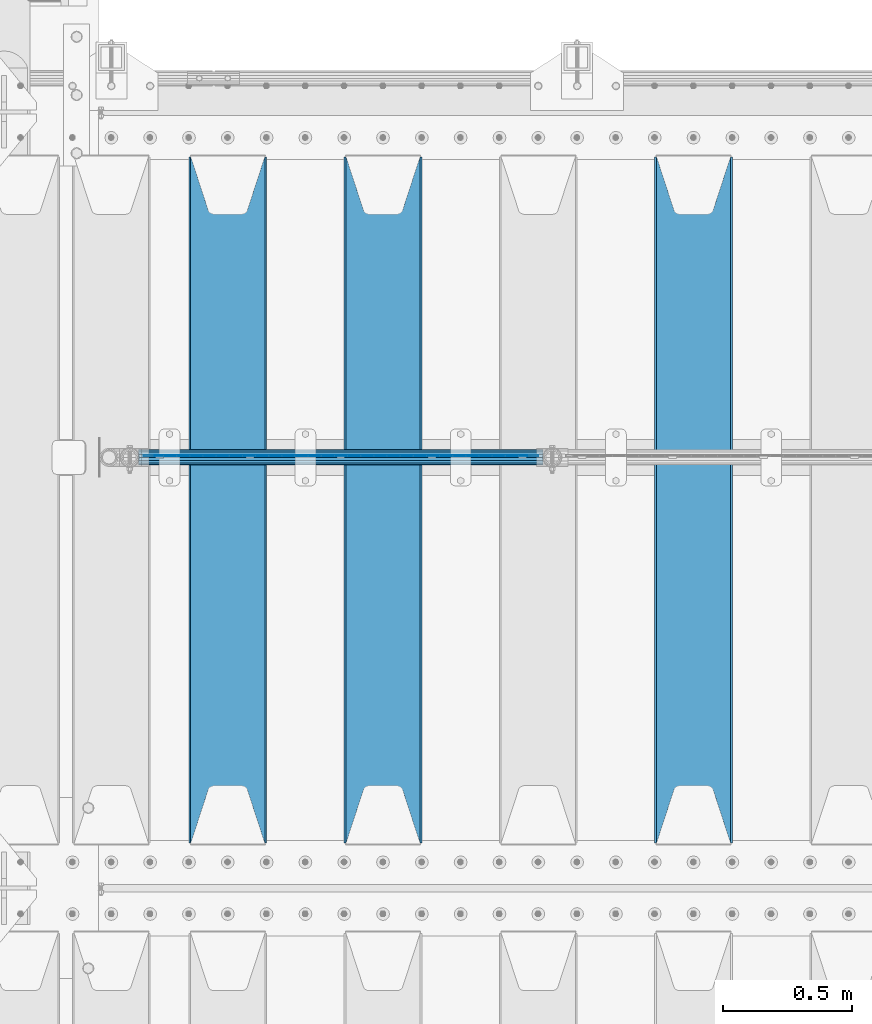
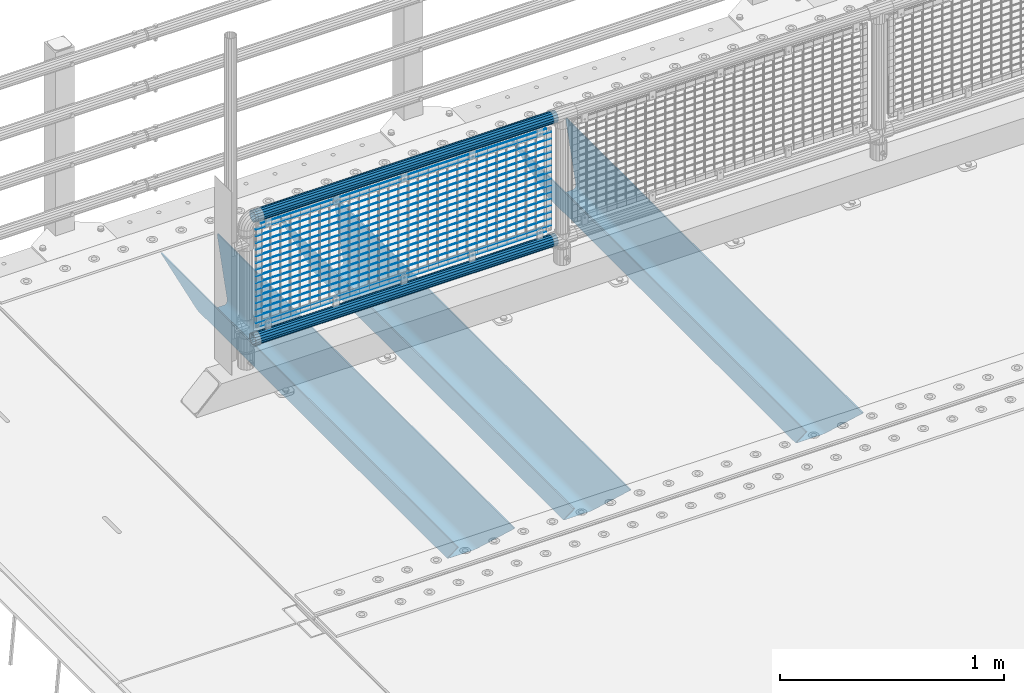
# One storey, part 128 of 270: 22 beams.
"""IFC2X3 building model written with IfcOpenShell, lengths in millimetres."""

from ifc_helpers import new_model, si_unit, frame, origin_with_axes, place, context, subcontext, project, spatial, faceted_brep, material, type_object, element, save


model = new_model("IFC2X3")

# Units and contexts
model_context = context("Model", 3, precision=1e-05, world=origin_with_axes())
body_context = subcontext(model_context, "Body", "Model", "MODEL_VIEW")
ifc_project = project(units=[si_unit("LENGTHUNIT", "METRE", prefix="MILLI"), si_unit("AREAUNIT", "SQUARE_METRE"), si_unit("VOLUMEUNIT", "CUBIC_METRE"), si_unit("MASSUNIT", "GRAM", prefix="KILO"), si_unit("TIMEUNIT", "SECOND"), si_unit("PLANEANGLEUNIT", "RADIAN"), si_unit("SOLIDANGLEUNIT", "STERADIAN"), si_unit("THERMODYNAMICTEMPERATUREUNIT", "DEGREE_CELSIUS"), si_unit("LUMINOUSINTENSITYUNIT", "LUMEN")], contexts=[model_context])

# Site, building, storey
site_placement = place(None, origin_with_axes())
site = spatial("IfcSite", under=ifc_project, at=site_placement, CompositionType="ELEMENT")
building_placement = place(site_placement, origin_with_axes())
building = spatial("IfcBuilding", under=site, at=building_placement, Name="Standard", CompositionType="ELEMENT")
storey_placement = place(building_placement, origin_with_axes())
storey = spatial("IfcBuildingStorey", under=building, at=storey_placement, Name="Undefined", CompositionType="ELEMENT", Elevation=0.0)

# Beams
ifc_material_1 = material(Name="STEEL/S355N")
beam_type_1 = type_object("IfcBeamType", PredefinedType="NOTDEFINED")
beam_1_placement = place(storey_placement, frame((2800.0, -17825.0, -115.0), z_axis=(0.0, 0.0, 1.0), x_axis=(0.0, 1.0, 0.0)))
element("IfcBeam", 1, at=beam_1_placement, inside=storey, type_object=beam_type_1, material=ifc_material_1, context=body_context, shape_type="Brep", body=[
    faceted_brep([(0.0, 150.0, 115.0), (0.0, 143.689999999999, 115.0), (2650.00000000297, 143.689999999999, 115.0), (2650.00000000297, 150.0, 115.0), (2650.00000000297, 142.059565218398, 110.000000003096), (2650.00000000297, 148.3695652184, 110.000000003096), (2441.90079219209, -80.1103600731112, -98.0992078077845), (2437.7588105432, -77.5672621345584, -102.241189456673), (2434.06523489747, -74.4080125315522, -105.934765102404), (2430.9108609509, -70.710272125576, -109.089139048974), (2428.37322971128, -66.5649389910068, -111.626770288588), (2426.51472138055, -62.0739139532889, -113.485278619323), (2425.38102192092, -57.3475956567672, -114.618978078955), (2424.99999999987, -52.5021667386536, -115.0), (2424.99999999987, 52.5021667386536, -115.0), (2425.38102192092, 57.3475956567672, -114.618978078955), (2426.51472138055, 62.0739139532889, -113.485278619323), (2428.37322971128, 66.5649389910068, -111.626770288588), (2430.9108609509, 70.710272125576, -109.089139048974), (2434.06523489747, 74.4080125315522, -105.934765102404), (2437.7588105432, 77.5672621345584, -102.241189456673), (2441.90079219209, 80.1103600731112, -98.0992078077846), (2446.38936140511, 81.9747917625791, -93.6106385947584), (2448.2494850041, 76.2713538057251, -91.7505149957729), (2444.62967112263, 74.76777986261, -95.3703288772456), (2441.28936334126, 72.7168944282894, -98.710636658607), (2438.31067330439, 70.1691124903846, -101.689326695487), (2435.76682334747, 67.1870637758839, -104.233176652398), (2433.72034654133, 63.8440531834895, -106.279653458539), (2432.22154950042, 60.222258798236, -107.778450499454), (2431.30727574265, 56.4107117849089, -108.692724257221), (2430.99999999987, 52.5031078186876, -109.0), (2430.99999999987, -52.5031078186876, -109.0), (2431.30727574265, -56.4107117849089, -108.692724257221), (2432.22154950042, -60.222258798236, -107.778450499454), (2433.72034654133, -63.8440531834895, -106.279653458539), (2435.76682334747, -67.1870637758839, -104.233176652398), (2438.31067330438, -70.1691124903846, -101.689326695487), (2441.28936334126, -72.7168944282894, -98.7106366586071), (2444.62967112263, -74.76777986261, -95.3703288772457), (2448.2494850041, -76.2713538057251, -91.7505149957729), (2650.00000000297, -142.059565218398, 110.000000003096), (2650.00000000297, -148.3695652184, 110.000000003096), (2446.38936140511, -81.9747917625791, -93.6106385947584), (2650.00000000297, -143.689999999999, 115.0), (2650.00000000297, -150.0, 115.0), (0.0, -143.689999999999, 115.0), (0.0, -150.0, 115.0), (0.0, -148.369565218261, 110.000000002672), (203.610638597431, -81.9747917625791, -93.6106385947584), (208.099207810457, -80.1103600731112, -98.0992078077845), (212.241189459342, -77.5672621345584, -102.241189456673), (215.934765105078, -74.4080125315522, -105.934765102404), (219.089139051644, -70.710272125576, -109.089139048974), (221.626770291259, -66.5649389910068, -111.626770288588), (223.485278621993, -62.0739139532889, -113.485278619323), (224.618978081628, -57.3475956567672, -114.618978078955), (225.00000000267, -52.5021667386536, -115.0), (225.00000000267, 52.5021667386536, -115.0), (224.618978081628, 57.3475956567672, -114.618978078955), (223.485278621993, 62.0739139532889, -113.485278619323), (221.626770291259, 66.5649389910068, -111.626770288588), (219.089139051644, 70.710272125576, -109.089139048974), (215.934765105078, 74.4080125315522, -105.934765102404), (212.241189459342, 77.5672621345584, -102.241189456673), (208.099207810457, 80.1103600731112, -98.0992078077846), (203.610638597431, 81.9747917625791, -93.6106385947584), (0.0, 148.369565218261, 110.000000002672), (0.0, 142.05956521826, 110.000000002672), (201.750514998446, 76.2713538057251, -91.7505149957729), (205.370328879915, 74.76777986261, -95.3703288772456), (208.710636661279, 72.7168944282894, -98.710636658607), (211.689326698157, 70.1691124903846, -101.689326695487), (214.233176655071, 67.1870637758839, -104.233176652398), (216.27965346121, 63.8440531834895, -106.279653458539), (217.778450502126, 60.222258798236, -107.778450499454), (218.692724259894, 56.4107117849089, -108.692724257221), (219.00000000267, 52.5031078186876, -109.0), (219.00000000267, -52.5031078186876, -109.0), (218.692724259894, -56.4107117849089, -108.692724257221), (217.778450502123, -60.222258798236, -107.778450499454), (216.27965346121, -63.8440531834895, -106.279653458539), (214.233176655071, -67.1870637758839, -104.233176652398), (211.689326698157, -70.1691124903846, -101.689326695487), (208.710636661279, -72.7168944282894, -98.7106366586071), (205.370328879915, -74.76777986261, -95.3703288772457), (201.750514998446, -76.2713538057251, -91.7505149957729), (0.0, -142.05956521826, 110.000000002672)], [[[0, 1, 2, 3]], [[3, 2, 4, 5]], [[6, 7, 8, 9, 10, 11, 12, 13, 14, 15, 16, 17, 18, 19, 20, 21, 22, 5, 4, 23, 24, 25, 26, 27, 28, 29, 30, 31, 32, 33, 34, 35, 36, 37, 38, 39, 40, 41, 42, 43]], [[44, 45, 42, 41]], [[46, 47, 45, 44]], [[43, 42, 45, 47, 48, 49]], [[6, 43, 49, 50]], [[7, 6, 50, 51]], [[8, 7, 51, 52]], [[9, 8, 52, 53]], [[10, 9, 53, 54]], [[11, 10, 54, 55]], [[12, 11, 55, 56]], [[13, 12, 56, 57]], [[14, 13, 57, 58]], [[15, 14, 58, 59]], [[16, 15, 59, 60]], [[17, 16, 60, 61]], [[18, 17, 61, 62]], [[19, 18, 62, 63]], [[20, 19, 63, 64]], [[21, 20, 64, 65]], [[22, 21, 65, 66]], [[0, 3, 5, 22, 66, 67]], [[1, 0, 67, 68]], [[23, 4, 2, 1, 68, 69]], [[24, 23, 69, 70]], [[25, 24, 70, 71]], [[26, 25, 71, 72]], [[27, 26, 72, 73]], [[28, 27, 73, 74]], [[29, 28, 74, 75]], [[30, 29, 75, 76]], [[31, 30, 76, 77]], [[32, 31, 77, 78]], [[33, 32, 78, 79]], [[34, 33, 79, 80]], [[35, 34, 80, 81]], [[36, 35, 81, 82]], [[37, 36, 82, 83]], [[38, 37, 83, 84]], [[39, 38, 84, 85]], [[40, 39, 85, 86]], [[46, 44, 41, 40, 86, 87]], [[47, 46, 87, 48]], [[86, 85, 84, 83, 82, 81, 80, 79, 78, 77, 76, 75, 74, 73, 72, 71, 70, 69, 68, 67, 66, 65, 64, 63, 62, 61, 60, 59, 58, 57, 56, 55, 54, 53, 52, 51, 50, 49, 48, 87]]]),
])
beam_2_placement = place(storey_placement, frame((1600.0, -17825.0, -115.0), z_axis=(0.0, 0.0, 1.0), x_axis=(0.0, 1.0, 0.0)))
element("IfcBeam", 2, at=beam_2_placement, inside=storey, type_object=beam_type_1, material=ifc_material_1, context=body_context, shape_type="Brep", body=[
    faceted_brep([(0.0, 150.0, 115.0), (0.0, 143.689999999999, 115.0), (2650.00000000297, 143.689999999999, 115.0), (2650.00000000297, 150.0, 115.0), (2650.00000000297, 142.059565218398, 110.000000003096), (2650.00000000297, 148.3695652184, 110.000000003096), (2441.90079219209, -80.1103600731112, -98.0992078077845), (2437.7588105432, -77.5672621345584, -102.241189456673), (2434.06523489747, -74.4080125315522, -105.934765102404), (2430.9108609509, -70.710272125576, -109.089139048974), (2428.37322971128, -66.5649389910068, -111.626770288588), (2426.51472138055, -62.0739139532889, -113.485278619323), (2425.38102192092, -57.3475956567672, -114.618978078955), (2424.99999999987, -52.5021667386536, -115.0), (2424.99999999987, 52.5021667386536, -115.0), (2425.38102192092, 57.3475956567672, -114.618978078955), (2426.51472138055, 62.0739139532889, -113.485278619323), (2428.37322971128, 66.5649389910068, -111.626770288588), (2430.9108609509, 70.710272125576, -109.089139048974), (2434.06523489747, 74.4080125315522, -105.934765102404), (2437.7588105432, 77.5672621345584, -102.241189456673), (2441.90079219209, 80.1103600731112, -98.0992078077846), (2446.38936140511, 81.9747917625791, -93.6106385947584), (2448.2494850041, 76.2713538057251, -91.7505149957729), (2444.62967112263, 74.76777986261, -95.3703288772456), (2441.28936334126, 72.7168944282894, -98.710636658607), (2438.31067330439, 70.1691124903846, -101.689326695487), (2435.76682334747, 67.1870637758839, -104.233176652398), (2433.72034654133, 63.8440531834895, -106.279653458539), (2432.22154950042, 60.222258798236, -107.778450499454), (2431.30727574265, 56.4107117849089, -108.692724257221), (2430.99999999987, 52.5031078186876, -109.0), (2430.99999999987, -52.5031078186876, -109.0), (2431.30727574265, -56.4107117849089, -108.692724257221), (2432.22154950042, -60.222258798236, -107.778450499454), (2433.72034654133, -63.8440531834895, -106.279653458539), (2435.76682334747, -67.1870637758839, -104.233176652398), (2438.31067330438, -70.1691124903846, -101.689326695487), (2441.28936334126, -72.7168944282894, -98.7106366586071), (2444.62967112263, -74.76777986261, -95.3703288772457), (2448.2494850041, -76.2713538057251, -91.7505149957729), (2650.00000000297, -142.059565218398, 110.000000003096), (2650.00000000297, -148.3695652184, 110.000000003096), (2446.38936140511, -81.9747917625791, -93.6106385947584), (2650.00000000297, -143.689999999999, 115.0), (2650.00000000297, -150.0, 115.0), (0.0, -143.689999999999, 115.0), (0.0, -150.0, 115.0), (0.0, -148.369565218261, 110.000000002672), (203.610638597431, -81.9747917625791, -93.6106385947584), (208.099207810457, -80.1103600731112, -98.0992078077845), (212.241189459342, -77.5672621345584, -102.241189456673), (215.934765105078, -74.4080125315522, -105.934765102404), (219.089139051644, -70.710272125576, -109.089139048974), (221.626770291259, -66.5649389910068, -111.626770288588), (223.485278621993, -62.0739139532889, -113.485278619323), (224.618978081628, -57.3475956567672, -114.618978078955), (225.00000000267, -52.5021667386536, -115.0), (225.00000000267, 52.5021667386536, -115.0), (224.618978081628, 57.3475956567672, -114.618978078955), (223.485278621993, 62.0739139532889, -113.485278619323), (221.626770291259, 66.5649389910068, -111.626770288588), (219.089139051644, 70.710272125576, -109.089139048974), (215.934765105078, 74.4080125315522, -105.934765102404), (212.241189459342, 77.5672621345584, -102.241189456673), (208.099207810457, 80.1103600731112, -98.0992078077846), (203.610638597431, 81.9747917625791, -93.6106385947584), (0.0, 148.369565218261, 110.000000002672), (0.0, 142.05956521826, 110.000000002672), (201.750514998446, 76.2713538057251, -91.7505149957729), (205.370328879915, 74.76777986261, -95.3703288772456), (208.710636661279, 72.7168944282894, -98.710636658607), (211.689326698157, 70.1691124903846, -101.689326695487), (214.233176655071, 67.1870637758839, -104.233176652398), (216.27965346121, 63.8440531834895, -106.279653458539), (217.778450502126, 60.222258798236, -107.778450499454), (218.692724259894, 56.4107117849089, -108.692724257221), (219.00000000267, 52.5031078186876, -109.0), (219.00000000267, -52.5031078186876, -109.0), (218.692724259894, -56.4107117849089, -108.692724257221), (217.778450502123, -60.222258798236, -107.778450499454), (216.27965346121, -63.8440531834895, -106.279653458539), (214.233176655071, -67.1870637758839, -104.233176652398), (211.689326698157, -70.1691124903846, -101.689326695487), (208.710636661279, -72.7168944282894, -98.7106366586071), (205.370328879915, -74.76777986261, -95.3703288772457), (201.750514998446, -76.2713538057251, -91.7505149957729), (0.0, -142.05956521826, 110.000000002672)], [[[0, 1, 2, 3]], [[3, 2, 4, 5]], [[6, 7, 8, 9, 10, 11, 12, 13, 14, 15, 16, 17, 18, 19, 20, 21, 22, 5, 4, 23, 24, 25, 26, 27, 28, 29, 30, 31, 32, 33, 34, 35, 36, 37, 38, 39, 40, 41, 42, 43]], [[44, 45, 42, 41]], [[46, 47, 45, 44]], [[43, 42, 45, 47, 48, 49]], [[6, 43, 49, 50]], [[7, 6, 50, 51]], [[8, 7, 51, 52]], [[9, 8, 52, 53]], [[10, 9, 53, 54]], [[11, 10, 54, 55]], [[12, 11, 55, 56]], [[13, 12, 56, 57]], [[14, 13, 57, 58]], [[15, 14, 58, 59]], [[16, 15, 59, 60]], [[17, 16, 60, 61]], [[18, 17, 61, 62]], [[19, 18, 62, 63]], [[20, 19, 63, 64]], [[21, 20, 64, 65]], [[22, 21, 65, 66]], [[0, 3, 5, 22, 66, 67]], [[1, 0, 67, 68]], [[23, 4, 2, 1, 68, 69]], [[24, 23, 69, 70]], [[25, 24, 70, 71]], [[26, 25, 71, 72]], [[27, 26, 72, 73]], [[28, 27, 73, 74]], [[29, 28, 74, 75]], [[30, 29, 75, 76]], [[31, 30, 76, 77]], [[32, 31, 77, 78]], [[33, 32, 78, 79]], [[34, 33, 79, 80]], [[35, 34, 80, 81]], [[36, 35, 81, 82]], [[37, 36, 82, 83]], [[38, 37, 83, 84]], [[39, 38, 84, 85]], [[40, 39, 85, 86]], [[46, 44, 41, 40, 86, 87]], [[47, 46, 87, 48]], [[86, 85, 84, 83, 82, 81, 80, 79, 78, 77, 76, 75, 74, 73, 72, 71, 70, 69, 68, 67, 66, 65, 64, 63, 62, 61, 60, 59, 58, 57, 56, 55, 54, 53, 52, 51, 50, 49, 48, 87]]]),
])
beam_3_placement = place(storey_placement, frame((1000.0, -17825.0, -115.0), z_axis=(0.0, 0.0, 1.0), x_axis=(0.0, 1.0, 0.0)))
element("IfcBeam", 3, at=beam_3_placement, inside=storey, type_object=beam_type_1, material=ifc_material_1, context=body_context, shape_type="Brep", body=[
    faceted_brep([(0.0, 150.0, 115.0), (0.0, 143.689999999999, 115.0), (2650.00000000297, 143.689999999999, 115.0), (2650.00000000297, 150.0, 115.0), (2650.00000000297, 142.059565218398, 110.000000003096), (2650.00000000297, 148.3695652184, 110.000000003096), (2441.90079219209, -80.1103600731112, -98.0992078077845), (2437.7588105432, -77.5672621345584, -102.241189456673), (2434.06523489747, -74.4080125315522, -105.934765102404), (2430.9108609509, -70.710272125576, -109.089139048974), (2428.37322971128, -66.5649389910068, -111.626770288588), (2426.51472138055, -62.0739139532889, -113.485278619323), (2425.38102192092, -57.3475956567672, -114.618978078955), (2424.99999999987, -52.5021667386536, -115.0), (2424.99999999987, 52.5021667386536, -115.0), (2425.38102192092, 57.3475956567672, -114.618978078955), (2426.51472138055, 62.0739139532889, -113.485278619323), (2428.37322971128, 66.5649389910068, -111.626770288588), (2430.9108609509, 70.710272125576, -109.089139048974), (2434.06523489747, 74.4080125315522, -105.934765102404), (2437.7588105432, 77.5672621345584, -102.241189456673), (2441.90079219209, 80.1103600731112, -98.0992078077846), (2446.38936140511, 81.9747917625791, -93.6106385947584), (2448.2494850041, 76.2713538057251, -91.7505149957729), (2444.62967112263, 74.76777986261, -95.3703288772456), (2441.28936334126, 72.7168944282894, -98.710636658607), (2438.31067330439, 70.1691124903846, -101.689326695487), (2435.76682334747, 67.1870637758839, -104.233176652398), (2433.72034654133, 63.8440531834895, -106.279653458539), (2432.22154950042, 60.222258798236, -107.778450499454), (2431.30727574265, 56.4107117849089, -108.692724257221), (2430.99999999987, 52.5031078186876, -109.0), (2430.99999999987, -52.5031078186876, -109.0), (2431.30727574265, -56.4107117849089, -108.692724257221), (2432.22154950042, -60.222258798236, -107.778450499454), (2433.72034654133, -63.8440531834895, -106.279653458539), (2435.76682334747, -67.1870637758839, -104.233176652398), (2438.31067330438, -70.1691124903846, -101.689326695487), (2441.28936334126, -72.7168944282894, -98.7106366586071), (2444.62967112263, -74.76777986261, -95.3703288772457), (2448.2494850041, -76.2713538057251, -91.7505149957729), (2650.00000000297, -142.059565218398, 110.000000003096), (2650.00000000297, -148.3695652184, 110.000000003096), (2446.38936140511, -81.9747917625791, -93.6106385947584), (2650.00000000297, -143.689999999999, 115.0), (2650.00000000297, -150.0, 115.0), (0.0, -143.689999999999, 115.0), (0.0, -150.0, 115.0), (0.0, -148.369565218261, 110.000000002672), (203.610638597431, -81.9747917625791, -93.6106385947584), (208.099207810457, -80.1103600731112, -98.0992078077845), (212.241189459342, -77.5672621345584, -102.241189456673), (215.934765105078, -74.4080125315522, -105.934765102404), (219.089139051644, -70.710272125576, -109.089139048974), (221.626770291259, -66.5649389910068, -111.626770288588), (223.485278621993, -62.0739139532889, -113.485278619323), (224.618978081628, -57.3475956567672, -114.618978078955), (225.00000000267, -52.5021667386536, -115.0), (225.00000000267, 52.5021667386536, -115.0), (224.618978081628, 57.3475956567672, -114.618978078955), (223.485278621993, 62.0739139532889, -113.485278619323), (221.626770291259, 66.5649389910068, -111.626770288588), (219.089139051644, 70.710272125576, -109.089139048974), (215.934765105078, 74.4080125315522, -105.934765102404), (212.241189459342, 77.5672621345584, -102.241189456673), (208.099207810457, 80.1103600731112, -98.0992078077846), (203.610638597431, 81.9747917625791, -93.6106385947584), (0.0, 148.369565218261, 110.000000002672), (0.0, 142.05956521826, 110.000000002672), (201.750514998446, 76.2713538057251, -91.7505149957729), (205.370328879915, 74.76777986261, -95.3703288772456), (208.710636661279, 72.7168944282894, -98.710636658607), (211.689326698157, 70.1691124903846, -101.689326695487), (214.233176655071, 67.1870637758839, -104.233176652398), (216.27965346121, 63.8440531834895, -106.279653458539), (217.778450502126, 60.222258798236, -107.778450499454), (218.692724259894, 56.4107117849089, -108.692724257221), (219.00000000267, 52.5031078186876, -109.0), (219.00000000267, -52.5031078186876, -109.0), (218.692724259894, -56.4107117849089, -108.692724257221), (217.778450502123, -60.222258798236, -107.778450499454), (216.27965346121, -63.8440531834895, -106.279653458539), (214.233176655071, -67.1870637758839, -104.233176652398), (211.689326698157, -70.1691124903846, -101.689326695487), (208.710636661279, -72.7168944282894, -98.7106366586071), (205.370328879915, -74.76777986261, -95.3703288772457), (201.750514998446, -76.2713538057251, -91.7505149957729), (0.0, -142.05956521826, 110.000000002672)], [[[0, 1, 2, 3]], [[3, 2, 4, 5]], [[6, 7, 8, 9, 10, 11, 12, 13, 14, 15, 16, 17, 18, 19, 20, 21, 22, 5, 4, 23, 24, 25, 26, 27, 28, 29, 30, 31, 32, 33, 34, 35, 36, 37, 38, 39, 40, 41, 42, 43]], [[44, 45, 42, 41]], [[46, 47, 45, 44]], [[43, 42, 45, 47, 48, 49]], [[6, 43, 49, 50]], [[7, 6, 50, 51]], [[8, 7, 51, 52]], [[9, 8, 52, 53]], [[10, 9, 53, 54]], [[11, 10, 54, 55]], [[12, 11, 55, 56]], [[13, 12, 56, 57]], [[14, 13, 57, 58]], [[15, 14, 58, 59]], [[16, 15, 59, 60]], [[17, 16, 60, 61]], [[18, 17, 61, 62]], [[19, 18, 62, 63]], [[20, 19, 63, 64]], [[21, 20, 64, 65]], [[22, 21, 65, 66]], [[0, 3, 5, 22, 66, 67]], [[1, 0, 67, 68]], [[23, 4, 2, 1, 68, 69]], [[24, 23, 69, 70]], [[25, 24, 70, 71]], [[26, 25, 71, 72]], [[27, 26, 72, 73]], [[28, 27, 73, 74]], [[29, 28, 74, 75]], [[30, 29, 75, 76]], [[31, 30, 76, 77]], [[32, 31, 77, 78]], [[33, 32, 78, 79]], [[34, 33, 79, 80]], [[35, 34, 80, 81]], [[36, 35, 81, 82]], [[37, 36, 82, 83]], [[38, 37, 83, 84]], [[39, 38, 84, 85]], [[40, 39, 85, 86]], [[46, 44, 41, 40, 86, 87]], [[47, 46, 87, 48]], [[86, 85, 84, 83, 82, 81, 80, 79, 78, 77, 76, 75, 74, 73, 72, 71, 70, 69, 68, 67, 66, 65, 64, 63, 62, 61, 60, 59, 58, 57, 56, 55, 54, 53, 52, 51, 50, 49, 48, 87]]]),
])
ifc_material_2 = material(Name="Misc_Undefined")
beam_type_2 = type_object("IfcBeamType", Name="D3", PredefinedType="NOTDEFINED")
for number, where, z_axis, x_axis in (
    (4, (676.0, -16329.5, 851.596999999999), (0.0, 0.0, 1.0), (1.0, 0.0, 0.0)),
    (5, (676.0, -16329.5, 669.452), (0.0, 0.0, 1.0), (1.0, 0.0, 0.0)),
    (6, (676.0, -16329.5, 523.736), (0.0, 0.0, 1.0), (1.0, 0.0, 0.0)),
    (7, (676.0, -16329.5, 487.307), (0.0, 0.0, 1.0), (1.0, 0.0, 0.0)),
    (8, (676.0, -16329.5, 705.881), (0.0, 0.0, 1.0), (1.0, 0.0, 0.0)),
    (9, (676.0, -16329.5, 596.594), (0.0, 0.0, 1.0), (1.0, 0.0, 0.0)),
    (10, (676.0, -16329.5, 450.878), (0.0, 0.0, 1.0), (1.0, 0.0, 0.0)),
    (11, (676.0, -16329.5, 815.167999999999), (0.0, 0.0, 1.0), (1.0, 0.0, 0.0)),
    (12, (676.0, -16329.5, 888.025999999999), (0.0, 0.0, 1.0), (1.0, 0.0, 0.0)),
    (13, (676.0, -16329.5, 778.738999999999), (0.0, 0.0, 1.0), (1.0, 0.0, 0.0)),
    (14, (676.0, -16329.5, 742.309999999999), (0.0, 0.0, 1.0), (1.0, 0.0, 0.0)),
    (15, (676.0, -16329.5, 633.023), (0.0, 0.0, 1.0), (1.0, 0.0, 0.0)),
    (16, (676.0, -16329.5, 560.165), (0.0, 0.0, 1.0), (1.0, 0.0, 0.0)),
    (17, (676.0, -16329.5, 414.449), (0.0, 0.0, 1.0), (1.0, 0.0, 0.0)),
):
    element("IfcBeam", number, at=place(storey_placement, frame(where, z_axis=z_axis, x_axis=x_axis)), inside=storey, type_object=beam_type_2, material=ifc_material_2, ObjectType="D3", context=body_context, shape_type="Brep", body=[
        faceted_brep([(0.0, -1.5, 0.0), (0.0, -0.75, -1.29903810567669), (1523.0, -0.75, -1.29903810567669), (1523.0, -1.5, 0.0), (0.0, 0.75, -1.29903810567669), (1523.0, 0.75, -1.29903810567669), (0.0, 1.5, 0.0), (1523.0, 1.5, 0.0), (0.0, 0.75, 1.29903810567669), (1523.0, 0.75, 1.29903810567669), (0.0, -0.75, 1.29903810567669), (1523.0, -0.75, 1.29903810567669)], [[[0, 1, 2, 3]], [[1, 4, 5, 2]], [[4, 6, 7, 5]], [[6, 8, 9, 7]], [[8, 10, 11, 9]], [[10, 0, 3, 11]], [[5, 7, 9, 11, 3, 2]], [[10, 8, 6, 4, 1, 0]]]),
    ])
beam_4_placement = place(storey_placement, frame((701.0, -16329.5, 353.02), z_axis=(0.0, 0.0, 1.0), x_axis=(1.0, 0.0, 0.0)))
element("IfcBeam", 18, at=beam_4_placement, inside=storey, type_object=beam_type_2, material=ifc_material_2, ObjectType="D3", context=body_context, shape_type="Brep", body=[
    faceted_brep([(0.0, -1.5, 0.0), (0.0, -0.75, -1.29903810567669), (1473.0, -0.75, -1.29903810567669), (1473.0, -1.5, 0.0), (0.0, 0.75, -1.29903810567669), (1473.0, 0.75, -1.29903810567663), (0.0, 1.5, 0.0), (1473.0, 1.5, 0.0), (0.0, 0.75, 1.29903810567669), (1473.0, 0.75, 1.29903810567669), (0.0, -0.75, 1.29903810567669), (1473.0, -0.75, 1.29903810567669)], [[[0, 1, 2, 3]], [[1, 4, 5, 2]], [[4, 6, 7, 5]], [[6, 8, 9, 7]], [[8, 10, 11, 9]], [[10, 0, 3, 11]], [[5, 7, 9, 11, 3, 2]], [[10, 8, 6, 4, 1, 0]]]),
])
beam_5_placement = place(storey_placement, frame((676.0, -16329.5, 378.02), z_axis=(0.0, 0.0, 1.0), x_axis=(1.0, 0.0, 0.0)))
element("IfcBeam", 19, at=beam_5_placement, inside=storey, type_object=beam_type_2, material=ifc_material_2, ObjectType="D3", context=body_context, shape_type="Brep", body=[
    faceted_brep([(0.0, -1.5, 0.0), (0.0, -0.75, -1.29903810567669), (1523.0, -0.75, -1.29903810567669), (1523.0, -1.5, 0.0), (0.0, 0.75, -1.29903810567669), (1523.0, 0.75, -1.29903810567669), (0.0, 1.5, 0.0), (1523.0, 1.5, 0.0), (0.0, 0.75, 1.29903810567669), (1523.0, 0.75, 1.29903810567669), (0.0, -0.75, 1.29903810567669), (1523.0, -0.75, 1.29903810567669)], [[[0, 1, 2, 3]], [[1, 4, 5, 2]], [[4, 6, 7, 5]], [[6, 8, 9, 7]], [[8, 10, 11, 9]], [[10, 0, 3, 11]], [[5, 7, 9, 11, 3, 2]], [[10, 8, 6, 4, 1, 0]]]),
])
beam_6_placement = place(storey_placement, frame((701.0, -16329.5, 913.02), z_axis=(0.0, 0.0, 1.0), x_axis=(1.0, 0.0, 0.0)))
element("IfcBeam", 20, at=beam_6_placement, inside=storey, type_object=beam_type_2, material=ifc_material_2, ObjectType="D3", context=body_context, shape_type="Brep", body=[
    faceted_brep([(0.0, -1.5, 0.0), (0.0, -0.75, -1.29903810567669), (1473.0, -0.75, -1.29903810567669), (1473.0, -1.5, 0.0), (0.0, 0.75, -1.29903810567669), (1473.0, 0.75, -1.29903810567663), (0.0, 1.5, 0.0), (1473.0, 1.5, 0.0), (0.0, 0.75, 1.29903810567669), (1473.0, 0.75, 1.29903810567669), (0.0, -0.75, 1.29903810567669), (1473.0, -0.75, 1.29903810567669)], [[[0, 1, 2, 3]], [[1, 4, 5, 2]], [[4, 6, 7, 5]], [[6, 8, 9, 7]], [[8, 10, 11, 9]], [[10, 0, 3, 11]], [[5, 7, 9, 11, 3, 2]], [[10, 8, 6, 4, 1, 0]]]),
])
ifc_material_3 = material()
beam_type_3 = type_object("IfcBeamType", PredefinedType="NOTDEFINED")
beam_7_placement = place(storey_placement, frame((655.85, -16335.5, 969.849999999999), z_axis=(0.0, 0.0, 1.0), x_axis=(1.0, 0.0, 0.0)))
element("IfcBeam", 21, at=beam_7_placement, inside=storey, type_object=beam_type_3, material=ifc_material_3, context=body_context, shape_type="Brep", body=[
    faceted_brep([(0.0, -25.3500000000004, 0.0), (0.0, -23.4203461491616, 9.70102501045403), (1563.0, -23.4203461491616, 9.70102501045506), (1563.0, -25.3500000000004, 0.0), (0.0, -17.9251569030785, 17.9251569030785), (1563.0, -17.9251569030785, 17.925156903079), (0.0, -9.70102501045585, 23.4203461491597), (1563.0, -9.70102501045585, 23.4203461491611), (0.0, 0.0, 25.3499999999985), (1563.0, 0.0, 25.35), (0.0, 9.70102501045585, 23.4203461491597), (1563.0, 9.70102501045585, 23.4203461491611), (0.0, 17.9251569030785, 17.9251569030785), (1563.0, 17.9251569030785, 17.925156903079), (0.0, 23.4203461491616, 9.70102501045403), (1563.0, 23.4203461491616, 9.70102501045506), (0.0, 25.3500000000004, 0.0), (1563.0, 25.3500000000004, 0.0), (0.0, 23.4203461491616, -9.70102501045403), (1563.0, 23.4203461491616, -9.70102501045506), (0.0, 17.9251569030785, -17.9251569030785), (1563.0, 17.9251569030785, -17.925156903079), (0.0, 9.70102501045585, -23.4203461491597), (1563.0, 9.70102501045585, -23.4203461491611), (0.0, 0.0, -25.3499999999985), (1563.0, 0.0, -25.35), (0.0, -9.70102501045585, -23.4203461491597), (1563.0, -9.70102501045585, -23.4203461491611), (0.0, -17.9251569030785, -17.9251569030785), (1563.0, -17.9251569030785, -17.925156903079), (0.0, -23.4203461491616, -9.70102501045403), (1563.0, -23.4203461491616, -9.70102501045506), (0.0, -30.1499999999996, 0.0), (0.0, -27.8549679052157, -11.5379054858058), (1563.0, -27.8549679052157, -11.5379054858075), (1563.0, -30.1499999999996, 0.0), (0.0, -21.3192694527752, -21.3192694527752), (1563.0, -21.3192694527752, -21.3192694527744), (0.0, -11.5379054858076, -27.8549679052157), (1563.0, -11.5379054858076, -27.8549679052153), (0.0, 0.0, -30.1500000000015), (1563.0, 0.0, -30.15), (0.0, 11.5379054858076, -27.8549679052157), (1563.0, 11.5379054858076, -27.8549679052153), (0.0, 21.3192694527752, -21.3192694527752), (1563.0, 21.3192694527752, -21.3192694527744), (0.0, 27.8549679052157, -11.5379054858058), (1563.0, 27.8549679052157, -11.5379054858074), (0.0, 30.1499999999996, 0.0), (1563.0, 30.1499999999996, 0.0), (0.0, 27.8549679052157, 11.5379054858058), (1563.0, 27.8549679052157, 11.5379054858074), (0.0, 21.3192694527752, 21.3192694527752), (1563.0, 21.3192694527752, 21.3192694527744), (0.0, 11.5379054858076, 27.8549679052157), (1563.0, 11.5379054858076, 27.8549679052153), (0.0, 0.0, 30.1500000000015), (1563.0, 0.0, 30.15), (0.0, -11.5379054858076, 27.8549679052157), (1563.0, -11.5379054858076, 27.8549679052153), (0.0, -21.3192694527752, 21.3192694527752), (1563.0, -21.3192694527752, 21.3192694527744), (0.0, -27.8549679052157, 11.5379054858058), (1563.0, -27.8549679052157, 11.5379054858074)], [[[0, 1, 2, 3]], [[1, 4, 5, 2]], [[4, 6, 7, 5]], [[6, 8, 9, 7]], [[8, 10, 11, 9]], [[10, 12, 13, 11]], [[12, 14, 15, 13]], [[14, 16, 17, 15]], [[16, 18, 19, 17]], [[18, 20, 21, 19]], [[20, 22, 23, 21]], [[22, 24, 25, 23]], [[24, 26, 27, 25]], [[26, 28, 29, 27]], [[28, 30, 31, 29]], [[30, 0, 3, 31]], [[32, 33, 34, 35]], [[33, 36, 37, 34]], [[36, 38, 39, 37]], [[38, 40, 41, 39]], [[40, 42, 43, 41]], [[42, 44, 45, 43]], [[44, 46, 47, 45]], [[46, 48, 49, 47]], [[48, 50, 51, 49]], [[50, 52, 53, 51]], [[52, 54, 55, 53]], [[54, 56, 57, 55]], [[56, 58, 59, 57]], [[58, 60, 61, 59]], [[60, 62, 63, 61]], [[62, 32, 35, 63]], [[37, 39, 41, 43, 45, 47, 49, 51, 53, 55, 57, 59, 61, 63, 35, 34], [5, 7, 9, 11, 13, 15, 17, 19, 21, 23, 25, 27, 29, 31, 3, 2]], [[62, 60, 58, 56, 54, 52, 50, 48, 46, 44, 42, 40, 38, 36, 33, 32], [30, 28, 26, 24, 22, 20, 18, 16, 14, 12, 10, 8, 6, 4, 1, 0]]]),
])
beam_8_placement = place(storey_placement, frame((655.850000000006, -16335.5, 298.170000000001), z_axis=(0.0, 0.0, 1.0), x_axis=(1.0, 0.0, 0.0)))
element("IfcBeam", 22, at=beam_8_placement, inside=storey, type_object=beam_type_3, material=ifc_material_3, context=body_context, shape_type="Brep", body=[
    faceted_brep([(0.0, -25.3500000000004, 0.0), (0.0, -23.4203461491616, 9.70102501045403), (1563.0, -23.4203461491616, 9.70102501045506), (1563.0, -25.3500000000004, 0.0), (0.0, -17.9251569030785, 17.9251569030785), (1563.0, -17.9251569030785, 17.925156903079), (0.0, -9.70102501045585, 23.4203461491597), (1563.0, -9.70102501045585, 23.4203461491611), (0.0, 0.0, 25.3499999999985), (1563.0, 0.0, 25.35), (0.0, 9.70102501045585, 23.4203461491597), (1563.0, 9.70102501045585, 23.4203461491611), (0.0, 17.9251569030785, 17.9251569030785), (1563.0, 17.9251569030785, 17.925156903079), (0.0, 23.4203461491616, 9.70102501045403), (1563.0, 23.4203461491616, 9.70102501045506), (0.0, 25.3500000000004, 0.0), (1563.0, 25.3500000000004, 0.0), (0.0, 23.4203461491616, -9.70102501045403), (1563.0, 23.4203461491616, -9.70102501045506), (0.0, 17.9251569030785, -17.9251569030785), (1563.0, 17.9251569030785, -17.925156903079), (0.0, 9.70102501045585, -23.4203461491597), (1563.0, 9.70102501045585, -23.4203461491611), (0.0, 0.0, -25.3499999999985), (1563.0, 0.0, -25.35), (0.0, -9.70102501045585, -23.4203461491597), (1563.0, -9.70102501045585, -23.4203461491611), (0.0, -17.9251569030785, -17.9251569030785), (1563.0, -17.9251569030785, -17.925156903079), (0.0, -23.4203461491616, -9.70102501045403), (1563.0, -23.4203461491616, -9.70102501045506), (0.0, -30.1499999999996, 0.0), (0.0, -27.8549679052157, -11.5379054858058), (1563.0, -27.8549679052157, -11.5379054858075), (1563.0, -30.1499999999996, 0.0), (0.0, -21.3192694527752, -21.3192694527752), (1563.0, -21.3192694527752, -21.3192694527744), (0.0, -11.5379054858076, -27.8549679052157), (1563.0, -11.5379054858076, -27.8549679052153), (0.0, 0.0, -30.1500000000015), (1563.0, 0.0, -30.15), (0.0, 11.5379054858076, -27.8549679052157), (1563.0, 11.5379054858076, -27.8549679052153), (0.0, 21.3192694527752, -21.3192694527752), (1563.0, 21.3192694527752, -21.3192694527744), (0.0, 27.8549679052157, -11.5379054858058), (1563.0, 27.8549679052157, -11.5379054858074), (0.0, 30.1499999999996, 0.0), (1563.0, 30.1499999999996, 0.0), (0.0, 27.8549679052157, 11.5379054858058), (1563.0, 27.8549679052157, 11.5379054858074), (0.0, 21.3192694527752, 21.3192694527752), (1563.0, 21.3192694527752, 21.3192694527744), (0.0, 11.5379054858076, 27.8549679052157), (1563.0, 11.5379054858076, 27.8549679052153), (0.0, 0.0, 30.1500000000015), (1563.0, 0.0, 30.15), (0.0, -11.5379054858076, 27.8549679052157), (1563.0, -11.5379054858076, 27.8549679052153), (0.0, -21.3192694527752, 21.3192694527752), (1563.0, -21.3192694527752, 21.3192694527744), (0.0, -27.8549679052157, 11.5379054858058), (1563.0, -27.8549679052157, 11.5379054858074)], [[[0, 1, 2, 3]], [[1, 4, 5, 2]], [[4, 6, 7, 5]], [[6, 8, 9, 7]], [[8, 10, 11, 9]], [[10, 12, 13, 11]], [[12, 14, 15, 13]], [[14, 16, 17, 15]], [[16, 18, 19, 17]], [[18, 20, 21, 19]], [[20, 22, 23, 21]], [[22, 24, 25, 23]], [[24, 26, 27, 25]], [[26, 28, 29, 27]], [[28, 30, 31, 29]], [[30, 0, 3, 31]], [[32, 33, 34, 35]], [[33, 36, 37, 34]], [[36, 38, 39, 37]], [[38, 40, 41, 39]], [[40, 42, 43, 41]], [[42, 44, 45, 43]], [[44, 46, 47, 45]], [[46, 48, 49, 47]], [[48, 50, 51, 49]], [[50, 52, 53, 51]], [[52, 54, 55, 53]], [[54, 56, 57, 55]], [[56, 58, 59, 57]], [[58, 60, 61, 59]], [[60, 62, 63, 61]], [[62, 32, 35, 63]], [[37, 39, 41, 43, 45, 47, 49, 51, 53, 55, 57, 59, 61, 63, 35, 34], [5, 7, 9, 11, 13, 15, 17, 19, 21, 23, 25, 27, 29, 31, 3, 2]], [[62, 60, 58, 56, 54, 52, 50, 48, 46, 44, 42, 40, 38, 36, 33, 32], [30, 28, 26, 24, 22, 20, 18, 16, 14, 12, 10, 8, 6, 4, 1, 0]]]),
])

save(model, "model.ifc")
